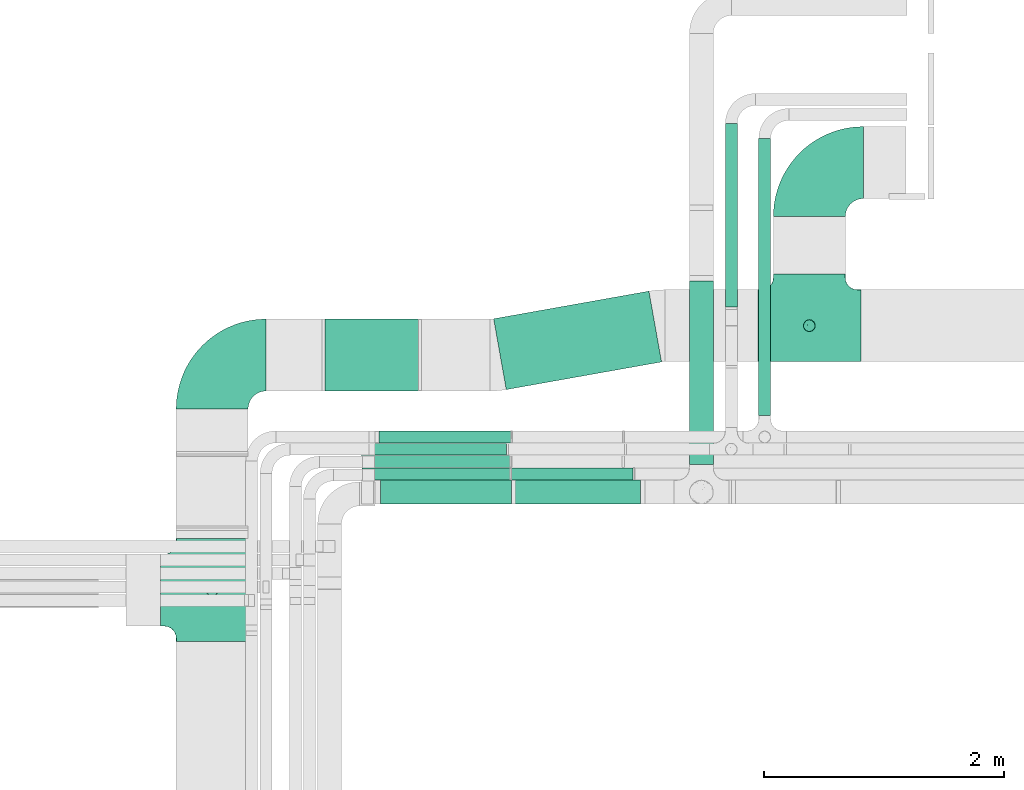
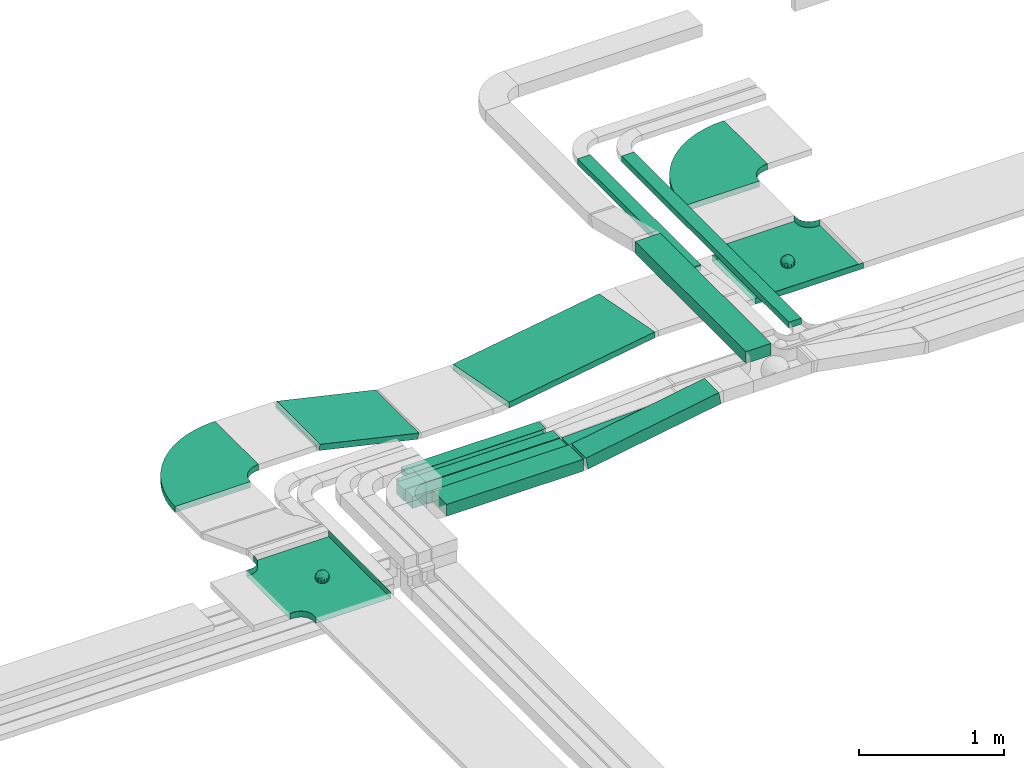
# One storey, part 2 of 28: 12 flow segments, 4 flow fittings.
"""IFC2X3 building model written with IfcOpenShell, lengths in millimetres."""

from ifc_helpers import new_model, entity, si_unit, converted_unit, derived_unit, direction, frame, frame_2d, origin, origin_2d_with_axis, place, context, subcontext, project, spatial, polyline, circle_curve, parameter, trimmed, segment, composite_curve, rectangle, outline, extrude, faceted_brep, source, transform, mapped, material, material_list, type_object, type_shapes, element, save


model = new_model("IFC2X3")

# Units and contexts
model_context = context("Model", 3, precision=0.01, world=origin(), true_north=direction((6.12303176911189e-17, 1.0)))
body_context = subcontext(model_context, "Body", "Model", "MODEL_VIEW")
ifc_project = project(units=[si_unit("LENGTHUNIT", "METRE", prefix="MILLI"), si_unit("AREAUNIT", "SQUARE_METRE"), si_unit("VOLUMEUNIT", "CUBIC_METRE"), converted_unit("PLANEANGLEUNIT", "DEGREE", entity("IfcRatioMeasure", 0.0174532925199433), si_unit("PLANEANGLEUNIT", "RADIAN"), dimensions=[0, 0, 0, 0, 0, 0, 0]), si_unit("MASSUNIT", "GRAM", prefix="KILO"), derived_unit("MASSDENSITYUNIT", [(si_unit("MASSUNIT", "GRAM", prefix="KILO"), 1), (si_unit("LENGTHUNIT", "METRE"), -3)]), derived_unit("MOMENTOFINERTIAUNIT", [(si_unit("LENGTHUNIT", "METRE"), 4)]), si_unit("TIMEUNIT", "SECOND"), si_unit("FREQUENCYUNIT", "HERTZ"), si_unit("THERMODYNAMICTEMPERATUREUNIT", "DEGREE_CELSIUS"), derived_unit("THERMALTRANSMITTANCEUNIT", [(si_unit("MASSUNIT", "GRAM", prefix="KILO"), 1), (si_unit("THERMODYNAMICTEMPERATUREUNIT", "KELVIN"), -1), (si_unit("TIMEUNIT", "SECOND"), -3)]), derived_unit("VOLUMETRICFLOWRATEUNIT", [(si_unit("LENGTHUNIT", "METRE"), 3), (si_unit("TIMEUNIT", "SECOND"), -1)]), derived_unit("MASSFLOWRATEUNIT", [(si_unit("MASSUNIT", "GRAM", prefix="KILO"), 1), (si_unit("TIMEUNIT", "SECOND"), -1)]), derived_unit("ROTATIONALFREQUENCYUNIT", [(si_unit("TIMEUNIT", "SECOND"), -1)]), si_unit("ELECTRICCURRENTUNIT", "AMPERE"), si_unit("ELECTRICVOLTAGEUNIT", "VOLT"), si_unit("POWERUNIT", "WATT"), si_unit("FORCEUNIT", "NEWTON", prefix="KILO"), si_unit("ILLUMINANCEUNIT", "LUX"), si_unit("LUMINOUSFLUXUNIT", "LUMEN"), si_unit("LUMINOUSINTENSITYUNIT", "CANDELA"), derived_unit("USERDEFINED", [(si_unit("MASSUNIT", "GRAM", prefix="KILO"), -1), (si_unit("LENGTHUNIT", "METRE"), -2), (si_unit("TIMEUNIT", "SECOND"), 3), (si_unit("LUMINOUSFLUXUNIT", "LUMEN"), 1)]), derived_unit("LINEARVELOCITYUNIT", [(si_unit("LENGTHUNIT", "METRE"), 1), (si_unit("TIMEUNIT", "SECOND"), -1)]), si_unit("PRESSUREUNIT", "PASCAL"), derived_unit("USERDEFINED", [(si_unit("LENGTHUNIT", "METRE"), -2), (si_unit("MASSUNIT", "GRAM", prefix="KILO"), 1), (si_unit("TIMEUNIT", "SECOND"), -2)]), derived_unit("LINEARFORCEUNIT", [(si_unit("MASSUNIT", "GRAM", prefix="KILO"), 1), (si_unit("LENGTHUNIT", "METRE"), 1), (si_unit("TIMEUNIT", "SECOND"), -2), (si_unit("LENGTHUNIT", "METRE"), -1)]), derived_unit("PLANARFORCEUNIT", [(si_unit("MASSUNIT", "GRAM", prefix="KILO"), 1), (si_unit("LENGTHUNIT", "METRE"), 1), (si_unit("TIMEUNIT", "SECOND"), -2), (si_unit("LENGTHUNIT", "METRE"), -2)])], contexts=[model_context])

# Site, building, storey
site_placement = place(None, origin())
site = spatial("IfcSite", under=ifc_project, at=site_placement, CompositionType="ELEMENT")
building_placement = place(site_placement, origin())
building = spatial("IfcBuilding", under=site, at=building_placement, CompositionType="ELEMENT")
storey_placement = place(building_placement, frame((0.0, 0.0, 4200.0)))
storey = spatial("IfcBuildingStorey", under=building, at=storey_placement, CompositionType="ELEMENT", Elevation=4200.0)

# Flow segments
cable_carrier_segment_type = type_object("IfcCableCarrierSegmentType", PredefinedType="CABLETRAYSEGMENT")
flow_segment_1_placement = place(storey_placement, frame((14783.07, 13087.04, 2750.0)))
element("IfcFlowSegment", 1, at=flow_segment_1_placement, inside=storey, type_object=cable_carrier_segment_type, context=body_context, shape_type="SweptSolid", body=[
    extrude(rectangle(XDim=1530.08411261918, YDim=99.9999999999989, at=origin_2d_with_axis()), frame((50.0, 765.04, 0.0), z_axis=(0.0, 0.0, 1.0), x_axis=(0.0, -1.0, 0.0)), (0.0, 0.0, 1.0), 49.9999999999995),
])
flow_segment_2_placement = place(storey_placement, frame((14483.54, 11773.79, 2904.06)))
element("IfcFlowSegment", 2, at=flow_segment_2_placement, inside=storey, type_object=cable_carrier_segment_type, context=body_context, shape_type="SweptSolid", body=[
    extrude(rectangle(XDim=1529.120177667, YDim=200.000000000002, at=origin_2d_with_axis()), frame((100.0, 764.56, 0.0), z_axis=(0.0, 0.0, 1.0), x_axis=(0.0, 1.0, 0.0)), (0.0, 0.0, 1.0), 99.9999999999989),
])
flow_segment_3_placement = place(storey_placement, frame((15061.77, 12184.03, 2750.0)))
element("IfcFlowSegment", 3, at=flow_segment_3_placement, inside=storey, type_object=cable_carrier_segment_type, context=body_context, shape_type="SweptSolid", body=[
    extrude(rectangle(XDim=2308.09524279726, YDim=99.9999999999989, at=origin_2d_with_axis()), frame((50.0, 1154.05, 0.0), z_axis=(0.0, 0.0, 1.0), x_axis=(0.0, 1.0, 0.0)), (0.0, 0.0, 1.0), 49.9999999999995),
])
flow_segment_4_placement = place(storey_placement, frame((12851.12, 12398.85, 2682.77)))
element("IfcFlowSegment", 4, at=flow_segment_4_placement, inside=storey, type_object=cable_carrier_segment_type, context=body_context, shape_type="SweptSolid", body=[
    extrude(rectangle(XDim=1315.61202745931, YDim=600.000000000002, at=origin_2d_with_axis()), frame((700.22, 410.7, 0.0), z_axis=(0.0, 0.0, 1.0), x_axis=(-0.98450467994016, -0.175358305123892, 0.0)), (0.0, 0.0, 1.0), 49.9999999999995),
])
flow_segment_5_placement = place(storey_placement, frame((13018.46, 11443.79, 2721.49)))
element("IfcFlowSegment", 5, at=flow_segment_5_placement, inside=storey, type_object=cable_carrier_segment_type, context=body_context, shape_type="SweptSolid", body=[
    extrude(rectangle(XDim=100.0, YDim=200.000000000002, at=origin_2d_with_axis()), frame((8.42, 100.0, 49.29), z_axis=(0.98571328393655, 0.0, 0.168431950267823), x_axis=(-0.168431950267823, 0.0, 0.98571328393655)), (0.0, 0.0, 1.0), 1074.28589873588),
])
flow_segment_6_placement = place(storey_placement, frame((11909.09, 11443.79, 2718.43)))
element("IfcFlowSegment", 6, at=flow_segment_6_placement, inside=storey, type_object=cable_carrier_segment_type, context=body_context, shape_type="SweptSolid", body=[
    extrude(rectangle(XDim=1090.17741149844, YDim=199.999999999998, at=origin_2d_with_axis()), frame((545.09, 100.0, 0.0), z_axis=(0.0, 0.0, 1.0), x_axis=(-1.0, 0.0, 0.0)), (0.0, 0.0, 1.0), 99.9999999999989),
])
flow_segment_7_placement = place(storey_placement, frame((11434.39, 12387.05, 2685.9)))
element("IfcFlowSegment", 7, at=flow_segment_7_placement, inside=storey, type_object=cable_carrier_segment_type, context=body_context, shape_type="SweptSolid", body=[
    extrude(rectangle(XDim=49.9999999999999, YDim=600.000000000002, at=frame_2d((0.0, 0.0), x_axis=(0.0, 1.0))), frame((5.58, 300.0, 204.65), z_axis=(0.974806096214138, 0.0, -0.223053972804235), x_axis=(0.0, 1.0, 0.0)), (0.0, 0.0, 1.0), 808.25585556279),
])
flow_segment_8_placement = place(storey_placement, frame((11753.82, 11646.85, 2715.23)))
element("IfcFlowSegment", 8, at=flow_segment_8_placement, inside=storey, type_object=cable_carrier_segment_type, context=body_context, shape_type="SweptSolid", body=[
    extrude(rectangle(XDim=1233.44098848929, YDim=99.9999999999989, at=origin_2d_with_axis()), frame((616.72, 50.0, 0.0), z_axis=(0.0, 0.0, 1.0), x_axis=(-1.0, 0.0, 0.0)), (0.0, 0.0, 1.0), 99.9999999999989),
])
flow_segment_9_placement = place(storey_placement, frame((12999.12, 11646.85, 2715.48)))
element("IfcFlowSegment", 9, at=flow_segment_9_placement, inside=storey, type_object=cable_carrier_segment_type, context=body_context, shape_type="SweptSolid", body=[
    extrude(rectangle(XDim=99.9999999999997, YDim=99.9999999999989, at=frame_2d((0.0, 0.0), x_axis=(0.0, 1.0))), frame((1.69, 50.0, 49.97), z_axis=(0.999429384266034, 0.0, 0.0337772980804675), x_axis=(0.0, 1.0, 0.0)), (0.0, 0.0, 1.0), 1015.96777318739),
])
flow_segment_10_placement = place(storey_placement, frame((11743.82, 11748.96, 2718.4)))
element("IfcFlowSegment", 10, at=flow_segment_10_placement, inside=storey, type_object=cable_carrier_segment_type, context=body_context, shape_type="SweptSolid", body=[
    extrude(rectangle(XDim=1243.22618576762, YDim=99.9999999999989, at=origin_2d_with_axis()), frame((621.61, 50.0, 0.0), z_axis=(0.0, 0.0, 1.0), x_axis=(-1.0, 0.0, 0.0)), (0.0, 0.0, 1.0), 99.9999999999989),
])
flow_segment_11_placement = place(storey_placement, frame((11800.87, 11851.53, 2718.4)))
element("IfcFlowSegment", 11, at=flow_segment_11_placement, inside=storey, type_object=cable_carrier_segment_type, context=body_context, shape_type="SweptSolid", body=[
    extrude(rectangle(XDim=1157.17723915463, YDim=99.9999999999989, at=origin_2d_with_axis()), frame((578.59, 50.0, 0.0), z_axis=(0.0, 0.0, 1.0), x_axis=(-1.0, 0.0, 0.0)), (0.0, 0.0, 1.0), 50.0000000000005),
])
flow_segment_12_placement = place(storey_placement, frame((11895.49, 11954.03, 2718.4)))
element("IfcFlowSegment", 12, at=flow_segment_12_placement, inside=storey, type_object=cable_carrier_segment_type, context=body_context, shape_type="SweptSolid", body=[
    extrude(rectangle(XDim=1098.44771651259, YDim=99.9999999999989, at=origin_2d_with_axis()), frame((549.22, 50.0, 0.0), z_axis=(0.0, 0.0, 1.0), x_axis=(-1.0, 0.0, 0.0)), (0.0, 0.0, 1.0), 49.9999999999995),
])

# Flow fittings
ifc_material_1 = material()
ifc_material_2 = material()
ifc_material_list = material_list([ifc_material_1, ifc_material_2])
cable_carrier_fitting_type_1 = type_object("IfcCableCarrierFittingType", PredefinedType="NOTDEFINED", material=ifc_material_1)
shared_shape_1 = source(origin(), body_context, "Body", "Brep", [
    faceted_brep([(43.65, -13.62, -20.22), (44.77, 0.0, -22.26), (48.26, -5.6, -11.81), (16.66, 5.33, -46.84), (11.56, -8.33, -47.93), (2.02, 2.7, -49.89), (-7.81, -35.95, -33.86), (-17.21, -38.27, -27.19), (-11.13, -27.32, -40.37), (37.7, -7.25, -32.03), (10.64, 26.52, -41.03), (19.21, 19.84, -41.68), (10.42, 17.81, -45.54), (48.75, 0.0, 0.0), (48.07, 6.52, -12.13), (-37.46, 12.16, -30.81), (-31.35, 12.15, -37.01), (-38.09, 3.52, -32.2), (48.75, 11.13, 0.0), (9.67, 42.57, -24.39), (17.48, 37.97, -27.43), (8.35, 35.36, -34.35), (36.7, 20.43, -27.12), (28.22, 12.58, -39.31), (28.4, 24.01, -33.43), (37.1, 7.75, -32.61), (30.39, 38.11, 0.0), (34.74, 34.64, 0.0), (32.94, 32.13, -19.56), (26.04, 41.58, 0.0), (-44.77, 0.0, -22.26), (-35.92, -8.72, -33.67), (-42.7, -12.19, -22.99), (5.42, -48.76, 0.0), (0.0, -48.78, -10.96), (7.59, -47.43, -13.88), (34.0, -31.65, -18.51), (40.01, -26.24, -14.51), (30.39, -38.11, 0.0), (-47.55, -8.65, -12.8), (43.92, -21.15, 0.0), (-47.55, 8.68, -12.81), (-43.92, 21.15, 0.0), (-41.56, 23.54, -14.78), (-36.7, 20.43, -27.12), (-42.68, 12.16, -23.03), (-0.04, -44.68, -22.44), (43.35, 13.13, -21.19), (-9.67, -42.82, -23.94), (2.93, -38.3, -32.0), (10.58, -32.36, -36.62), (17.48, -37.97, -27.43), (29.42, -14.29, -37.82), (29.26, 0.0, -40.54), (-34.74, 34.64, 0.0), (-35.59, 30.87, -16.74), (16.27, 46.29, 0.0), (15.4, 45.37, -14.3), (10.85, 47.52, 0.0), (-22.09, 42.26, -15.04), (-16.27, 46.29, 0.0), (-15.4, 45.37, -14.3), (-35.57, -30.88, -16.76), (-34.74, -34.64, 0.0), (-41.54, -23.57, -14.78), (-21.2, -29.91, -34.0), (-22.09, -42.26, -15.04), (-28.59, -35.77, -20.07), (27.97, -26.92, -31.51), (26.56, -36.75, -21.06), (-4.7, -12.82, -48.1), (-3.71, -22.05, -44.72), (0.0, -29.85, -40.11), (-8.78, 23.47, -43.27), (-10.71, 12.15, -47.3), (-19.19, 19.81, -41.71), (19.21, -19.84, -41.68), (10.27, -43.25, -22.88), (-16.27, -46.29, 0.0), (-15.42, -45.43, -14.08), (-10.85, -47.52, 0.0), (-21.69, -45.05, 0.0), (-26.04, -41.58, 0.0), (-30.39, -38.11, 0.0), (-26.91, -11.71, -40.48), (-28.57, -22.53, -34.29), (-14.35, 0.55, -47.89), (20.39, 29.7, -34.67), (25.88, 35.56, -23.78), (-1.9, 38.3, -32.09), (-0.04, 44.68, -22.44), (-9.54, 42.67, -24.26), (-10.12, 33.04, -36.14), (-17.21, 38.27, -27.19), (-28.59, 35.77, -20.07), (-30.39, 38.11, 0.0), (-26.04, 41.58, 0.0), (-21.69, 45.05, 0.0), (0.92, 16.99, -47.01), (0.0, 29.85, -40.11), (-28.43, 23.64, -33.66), (22.08, -42.72, -13.7), (0.0, -50.0, 0.0), (-7.98, 47.29, -14.15), (-10.85, 47.52, 0.0), (-5.42, 48.76, 0.0), (-39.09, -31.17, 0.0), (-36.7, -20.43, -27.12), (-20.05, 29.88, -34.71), (48.75, -11.13, 0.0), (36.7, -20.43, -27.12), (39.09, -31.17, 0.0), (43.92, 21.15, 0.0), (41.04, 24.48, -14.72), (21.43, -9.87, -44.08), (19.85, -30.3, -34.47), (26.04, -41.58, 0.0), (8.28, -22.62, -43.82), (-19.19, -19.81, -41.71), (-17.56, -9.66, -45.81), (-29.26, 0.0, -40.54), (-22.28, 8.45, -43.96), (21.69, -45.05, 0.0), (-7.75, -47.32, -14.15), (22.09, 42.36, -14.75), (21.69, 45.05, 0.0), (7.94, 47.25, -14.29), (5.42, 48.76, 0.0), (-43.92, -21.15, 0.0), (-39.09, 31.17, 0.0), (-48.75, 11.13, 0.0), (-48.75, -11.13, 0.0), (-48.75, 0.0, 0.0), (0.0, 50.0, 0.0), (0.0, 48.77, -11.04), (-5.42, -48.76, 0.0), (16.27, -46.29, 0.0), (10.85, -47.52, 0.0), (39.09, 31.17, 0.0), (34.74, -34.64, 0.0), (-43.65, -13.62, 20.22), (-44.77, 0.0, 22.26), (-48.26, -5.6, 11.81), (-16.66, 5.33, 46.84), (-11.56, -8.33, 47.93), (-2.02, 2.7, 49.89), (7.81, -35.95, 33.86), (17.21, -38.27, 27.19), (11.13, -27.32, 40.37), (-37.7, -7.25, 32.03), (-10.64, 26.52, 41.03), (-19.21, 19.84, 41.68), (-10.42, 17.81, 45.54), (-48.07, 6.52, 12.13), (37.46, 12.16, 30.81), (31.35, 12.15, 37.01), (38.09, 3.52, 32.2), (-9.67, 42.57, 24.39), (-17.48, 37.97, 27.43), (-8.35, 35.36, 34.35), (-36.7, 20.43, 27.12), (-28.22, 12.58, 39.31), (-28.4, 24.01, 33.43), (-37.1, 7.75, 32.61), (-32.94, 32.13, 19.56), (44.77, 0.0, 22.26), (35.92, -8.72, 33.67), (42.7, -12.19, 22.99), (0.0, -48.78, 10.96), (-7.59, -47.43, 13.88), (-34.0, -31.65, 18.51), (-40.01, -26.24, 14.51), (47.55, -8.65, 12.8), (47.55, 8.68, 12.81), (41.56, 23.54, 14.78), (36.7, 20.43, 27.12), (42.68, 12.16, 23.03), (0.04, -44.68, 22.44), (-43.35, 13.13, 21.19), (9.67, -42.82, 23.94), (-2.93, -38.3, 32.0), (-10.58, -32.36, 36.62), (-17.48, -37.97, 27.43), (-29.42, -14.29, 37.82), (-29.26, 0.0, 40.54), (35.59, 30.87, 16.74), (-15.4, 45.37, 14.3), (22.09, 42.26, 15.04), (15.4, 45.37, 14.3), (35.57, -30.88, 16.76), (41.54, -23.57, 14.78), (21.2, -29.91, 34.0), (22.09, -42.26, 15.04), (28.59, -35.77, 20.07), (-27.97, -26.92, 31.51), (-26.56, -36.75, 21.06), (4.7, -12.82, 48.1), (3.71, -22.05, 44.72), (0.0, -29.85, 40.11), (8.78, 23.47, 43.27), (10.71, 12.15, 47.3), (19.19, 19.81, 41.71), (-19.21, -19.84, 41.68), (-10.27, -43.25, 22.88), (15.42, -45.43, 14.08), (26.91, -11.71, 40.48), (28.57, -22.53, 34.29), (14.35, 0.55, 47.89), (-20.39, 29.7, 34.67), (-25.88, 35.56, 23.78), (1.9, 38.3, 32.09), (0.04, 44.68, 22.44), (9.54, 42.67, 24.26), (10.12, 33.04, 36.14), (17.21, 38.27, 27.19), (28.59, 35.77, 20.07), (-0.92, 16.99, 47.01), (0.0, 29.85, 40.11), (28.43, 23.64, 33.66), (-22.08, -42.72, 13.7), (7.98, 47.29, 14.15), (36.7, -20.43, 27.12), (20.05, 29.88, 34.71), (-36.7, -20.43, 27.12), (-41.04, 24.48, 14.72), (-21.43, -9.87, 44.08), (-19.85, -30.3, 34.47), (-8.28, -22.62, 43.82), (19.19, -19.81, 41.71), (17.56, -9.66, 45.81), (29.26, 0.0, 40.54), (22.28, 8.45, 43.96), (7.75, -47.32, 14.15), (-22.09, 42.36, 14.75), (-7.94, 47.25, 14.29), (0.0, 48.77, 11.04)], [[[0, 1, 2]], [[3, 4, 5]], [[6, 7, 8]], [[1, 0, 9]], [[10, 11, 12]], [[13, 2, 14]], [[15, 16, 17]], [[14, 18, 13]], [[19, 20, 21]], [[22, 23, 24]], [[1, 9, 25]], [[26, 27, 28, 29]], [[30, 31, 32]], [[33, 34, 35]], [[36, 37, 38]], [[32, 39, 30]], [[2, 40, 0]], [[23, 22, 25]], [[41, 42, 43]], [[44, 15, 45]], [[46, 35, 34]], [[25, 22, 47]], [[31, 30, 17]], [[48, 49, 46]], [[50, 51, 49]], [[52, 53, 9]], [[43, 54, 55]], [[56, 57, 58]], [[59, 60, 61]], [[62, 63, 64]], [[8, 7, 65]], [[7, 66, 67]], [[68, 36, 69]], [[70, 5, 4]], [[8, 71, 72]], [[73, 74, 75]], [[68, 76, 52]], [[77, 46, 49]], [[78, 79, 80]], [[7, 6, 48]], [[67, 81, 82, 83]], [[84, 85, 31]], [[85, 65, 67]], [[70, 86, 5]], [[23, 3, 11]], [[21, 87, 10]], [[21, 20, 87]], [[28, 24, 88]], [[19, 89, 90]], [[91, 90, 89]], [[91, 92, 93]], [[94, 95, 96, 97]], [[98, 99, 10]], [[100, 16, 44]], [[77, 51, 101]], [[33, 102, 34]], [[103, 91, 61]], [[93, 59, 61]], [[104, 105, 103]], [[106, 64, 63]], [[107, 31, 85]], [[100, 94, 108]], [[108, 93, 92]], [[43, 55, 44]], [[0, 40, 37]], [[2, 13, 109]], [[2, 1, 14]], [[110, 9, 0]], [[2, 109, 40]], [[37, 40, 111]], [[47, 14, 1]], [[112, 14, 47]], [[113, 112, 47]], [[112, 18, 14]], [[47, 22, 113]], [[52, 9, 110]], [[53, 25, 9]], [[25, 47, 1]], [[23, 25, 53]], [[68, 52, 110]], [[76, 4, 114]], [[51, 115, 69]], [[50, 115, 51]], [[110, 36, 68]], [[3, 23, 53]], [[23, 11, 24]], [[52, 76, 114]], [[98, 12, 5]], [[11, 87, 24]], [[24, 28, 22]], [[87, 88, 24]], [[36, 116, 69]], [[28, 27, 113]], [[114, 3, 53]], [[76, 115, 117]], [[70, 4, 117]], [[118, 84, 119]], [[119, 70, 118]], [[120, 16, 121]], [[37, 36, 110]], [[116, 36, 38]], [[116, 122, 69]], [[34, 123, 46]], [[10, 87, 11]], [[87, 20, 88]], [[12, 98, 10]], [[10, 99, 21]], [[74, 5, 86]], [[73, 75, 108]], [[124, 56, 125]], [[124, 29, 88]], [[89, 21, 99]], [[21, 89, 19]], [[92, 89, 99]], [[89, 92, 91]], [[126, 127, 58]], [[88, 29, 28]], [[20, 57, 124]], [[88, 20, 124]], [[57, 20, 19]], [[73, 92, 99]], [[92, 73, 108]], [[99, 98, 73]], [[74, 86, 121]], [[73, 98, 74]], [[5, 74, 98]], [[100, 108, 75]], [[94, 93, 108]], [[86, 120, 121]], [[100, 44, 55]], [[75, 16, 100]], [[17, 16, 120]], [[31, 17, 120]], [[17, 30, 45]], [[84, 31, 120]], [[31, 107, 32]], [[41, 45, 30]], [[43, 44, 45]], [[107, 64, 32]], [[39, 64, 128]], [[30, 39, 41]], [[129, 43, 42]], [[41, 130, 42]], [[43, 45, 41]], [[62, 83, 63]], [[95, 94, 55]], [[100, 55, 94]], [[64, 107, 62]], [[131, 39, 128]], [[64, 106, 128]], [[85, 62, 107]], [[67, 83, 62]], [[39, 32, 64]], [[130, 41, 132]], [[59, 97, 60]], [[133, 127, 134]], [[59, 94, 97]], [[104, 61, 60]], [[94, 59, 93]], [[126, 134, 127]], [[126, 58, 57]], [[19, 90, 126]], [[134, 105, 133]], [[126, 90, 134]], [[103, 90, 91]], [[105, 134, 103]], [[90, 103, 134]], [[119, 120, 86]], [[84, 118, 85]], [[65, 85, 118]], [[62, 85, 67]], [[8, 65, 118]], [[67, 65, 7]], [[71, 118, 70]], [[8, 72, 6]], [[49, 6, 72]], [[6, 49, 48]], [[50, 49, 72]], [[77, 49, 51]], [[101, 69, 122]], [[123, 34, 135]], [[101, 122, 136]], [[137, 77, 136]], [[78, 81, 66]], [[7, 79, 66]], [[67, 66, 81]], [[79, 7, 48]], [[35, 137, 33]], [[123, 80, 79]], [[135, 34, 102]], [[35, 46, 77]], [[80, 123, 135]], [[46, 123, 48]], [[117, 50, 72]], [[115, 76, 68]], [[117, 72, 71]], [[4, 76, 117]], [[39, 132, 41]], [[39, 131, 132]], [[137, 35, 77]], [[124, 57, 56]], [[126, 57, 19]], [[103, 61, 104]], [[61, 91, 93]], [[77, 101, 136]], [[51, 69, 101]], [[28, 113, 22]], [[112, 113, 138]], [[16, 75, 121]], [[74, 121, 75]], [[66, 79, 78]], [[123, 79, 48]], [[0, 37, 110]], [[37, 111, 139, 38]], [[29, 124, 125]], [[115, 50, 117]], [[69, 115, 68]], [[120, 119, 84]], [[70, 119, 86]], [[11, 3, 12]], [[5, 12, 3]], [[118, 71, 8]], [[117, 71, 70]], [[3, 114, 4]], [[53, 52, 114]], [[27, 138, 113]], [[45, 15, 17]], [[44, 16, 15]], [[55, 54, 95]], [[43, 129, 54]], [[140, 141, 142]], [[143, 144, 145]], [[146, 147, 148]], [[141, 140, 149]], [[150, 151, 152]], [[132, 142, 153]], [[154, 155, 156]], [[153, 130, 132]], [[157, 158, 159]], [[160, 161, 162]], [[141, 149, 163]], [[95, 54, 164, 96]], [[165, 166, 167]], [[135, 168, 169]], [[170, 171, 83]], [[167, 172, 165]], [[142, 141, 153]], [[161, 160, 163]], [[173, 112, 174]], [[175, 154, 176]], [[177, 169, 168]], [[163, 160, 178]], [[166, 165, 156]], [[179, 180, 177]], [[181, 182, 180]], [[183, 184, 149]], [[174, 27, 185]], [[60, 186, 104]], [[187, 56, 188]], [[189, 139, 190]], [[148, 147, 191]], [[147, 192, 193]], [[194, 170, 195]], [[196, 145, 144]], [[148, 197, 198]], [[199, 200, 201]], [[194, 202, 183]], [[203, 177, 180]], [[136, 204, 137]], [[147, 146, 179]], [[193, 122, 116, 38]], [[205, 206, 166]], [[206, 191, 193]], [[196, 207, 145]], [[161, 143, 151]], [[159, 208, 150]], [[159, 158, 208]], [[164, 162, 209]], [[157, 210, 211]], [[212, 211, 210]], [[212, 213, 214]], [[215, 26, 29, 125]], [[216, 217, 150]], [[218, 155, 175]], [[203, 182, 219]], [[135, 102, 168]], [[220, 212, 188]], [[214, 187, 188]], [[58, 127, 220]], [[111, 190, 139]], [[221, 166, 206]], [[218, 215, 222]], [[222, 214, 213]], [[174, 185, 175]], [[171, 140, 128]], [[132, 131, 142]], [[142, 128, 140]], [[223, 149, 140]], [[142, 131, 128]], [[171, 128, 106]], [[178, 153, 141]], [[42, 153, 178]], [[224, 42, 178]], [[42, 130, 153]], [[178, 160, 224]], [[183, 149, 223]], [[184, 163, 149]], [[163, 178, 141]], [[161, 163, 184]], [[194, 183, 223]], [[202, 144, 225]], [[182, 226, 195]], [[181, 226, 182]], [[223, 170, 194]], [[143, 161, 184]], [[161, 151, 162]], [[183, 202, 225]], [[216, 152, 145]], [[151, 208, 162]], [[162, 164, 160]], [[208, 209, 162]], [[170, 82, 195]], [[164, 54, 224]], [[225, 143, 184]], [[202, 226, 227]], [[196, 144, 227]], [[228, 205, 229]], [[229, 196, 228]], [[230, 155, 231]], [[171, 170, 223]], [[82, 170, 83]], [[82, 81, 195]], [[168, 232, 177]], [[150, 208, 151]], [[208, 158, 209]], [[152, 216, 150]], [[150, 217, 159]], [[200, 145, 207]], [[199, 201, 222]], [[233, 60, 97]], [[233, 96, 209]], [[210, 159, 217]], [[159, 210, 157]], [[213, 210, 217]], [[210, 213, 212]], [[234, 105, 104]], [[209, 96, 164]], [[158, 186, 233]], [[209, 158, 233]], [[186, 158, 157]], [[199, 213, 217]], [[213, 199, 222]], [[217, 216, 199]], [[200, 207, 231]], [[199, 216, 200]], [[145, 200, 216]], [[218, 222, 201]], [[215, 214, 222]], [[207, 230, 231]], [[218, 175, 185]], [[201, 155, 218]], [[156, 155, 230]], [[166, 156, 230]], [[156, 165, 176]], [[205, 166, 230]], [[166, 221, 167]], [[173, 176, 165]], [[174, 175, 176]], [[221, 190, 167]], [[172, 190, 40]], [[165, 172, 173]], [[138, 174, 112]], [[173, 18, 112]], [[174, 176, 173]], [[189, 38, 139]], [[26, 215, 185]], [[218, 185, 215]], [[190, 221, 189]], [[109, 172, 40]], [[190, 111, 40]], [[206, 189, 221]], [[193, 38, 189]], [[172, 167, 190]], [[18, 173, 13]], [[187, 125, 56]], [[133, 105, 235]], [[187, 215, 125]], [[58, 188, 56]], [[215, 187, 214]], [[234, 235, 105]], [[234, 104, 186]], [[157, 211, 234]], [[235, 127, 133]], [[234, 211, 235]], [[220, 211, 212]], [[127, 235, 220]], [[211, 220, 235]], [[229, 230, 207]], [[205, 228, 206]], [[191, 206, 228]], [[189, 206, 193]], [[148, 191, 228]], [[193, 191, 147]], [[197, 228, 196]], [[148, 198, 146]], [[180, 146, 198]], [[146, 180, 179]], [[181, 180, 198]], [[203, 180, 182]], [[219, 195, 81]], [[232, 168, 33]], [[219, 81, 78]], [[80, 203, 78]], [[136, 122, 192]], [[147, 204, 192]], [[193, 192, 122]], [[204, 147, 179]], [[169, 80, 135]], [[232, 137, 204]], [[33, 168, 102]], [[169, 177, 203]], [[137, 232, 33]], [[177, 232, 179]], [[227, 181, 198]], [[226, 202, 194]], [[227, 198, 197]], [[144, 202, 227]], [[172, 13, 173]], [[172, 109, 13]], [[80, 169, 203]], [[233, 186, 60]], [[234, 186, 157]], [[220, 188, 58]], [[188, 212, 214]], [[203, 219, 78]], [[182, 195, 219]], [[164, 224, 160]], [[42, 224, 129]], [[155, 201, 231]], [[200, 231, 201]], [[192, 204, 136]], [[232, 204, 179]], [[140, 171, 223]], [[171, 106, 63, 83]], [[96, 233, 97]], [[226, 181, 227]], [[195, 226, 194]], [[230, 229, 205]], [[196, 229, 207]], [[151, 143, 152]], [[145, 152, 143]], [[228, 197, 148]], [[227, 197, 196]], [[143, 225, 144]], [[184, 183, 225]], [[54, 129, 224]], [[176, 154, 156]], [[175, 155, 154]], [[185, 27, 26]], [[174, 138, 27]]]),
    faceted_brep([(-303.41, -374.12, 25.0), (-300.0, -400.0, 25.0), (-300.0, -430.0, 25.0), (-299.2, -430.0, 25.0), (-299.2, -400.0, 25.0), (-302.63, -373.91, 25.0), (-312.7, -349.6, 25.0), (-328.72, -328.72, 25.0), (-349.6, -312.7, 25.0), (-373.91, -302.63, 25.0), (-400.0, -299.2, 25.0), (-430.0, -299.2, 25.0), (-430.0, -300.0, 25.0), (-400.0, -300.0, 25.0), (-374.12, -303.41, 25.0), (-350.0, -313.4, 25.0), (-329.29, -329.29, 25.0), (-313.4, -350.0, 25.0), (430.0, -300.0, 25.0), (430.0, -299.2, 25.0), (400.0, -299.2, 25.0), (373.91, -302.63, 25.0), (349.6, -312.7, 25.0), (328.72, -328.72, 25.0), (312.7, -349.6, 25.0), (302.63, -373.91, 25.0), (299.2, -400.0, 25.0), (299.2, -430.0, 25.0), (300.0, -430.0, 25.0), (300.0, -400.0, 25.0), (303.41, -374.12, 25.0), (313.4, -350.0, 25.0), (329.29, -329.29, 25.0), (350.0, -313.4, 25.0), (374.12, -303.41, 25.0), (400.0, -300.0, 25.0), (430.0, 299.2, 25.0), (430.0, 300.0, 25.0), (-430.0, 300.0, 25.0), (-430.0, 299.2, 25.0), (-430.0, -300.0, -25.0), (-430.0, 300.0, -25.0), (430.0, 300.0, -25.0), (430.0, -300.0, -25.0), (400.0, -300.0, -25.0), (374.12, -303.41, -25.0), (350.0, -313.4, -25.0), (329.29, -329.29, -25.0), (313.4, -350.0, -25.0), (303.41, -374.12, -25.0), (300.0, -400.0, -25.0), (300.0, -430.0, -25.0), (-300.0, -430.0, -25.0), (-300.0, -400.0, -25.0), (-303.41, -374.12, -25.0), (-313.4, -350.0, -25.0), (-329.29, -329.29, -25.0), (-350.0, -313.4, -25.0), (-374.12, -303.41, -25.0), (-400.0, -300.0, -25.0), (-300.0, -400.0, -24.2), (299.2, -430.0, -24.2), (-299.2, -430.0, -24.2), (-299.2, -400.0, -24.2), (-400.0, -299.2, -24.2), (-430.0, -299.2, -24.2), (430.0, -299.2, -24.2), (400.0, -299.2, -24.2), (-430.0, 299.2, -24.2), (-400.0, -300.0, -24.2), (400.0, -300.0, -24.2), (430.0, 299.2, -24.2), (299.2, -400.0, -24.2), (300.0, -400.0, -24.2), (-373.91, -302.63, -24.2), (-349.6, -312.7, -24.2), (-328.72, -328.72, -24.2), (-312.7, -349.6, -24.2), (-302.63, -373.91, -24.2), (302.63, -373.91, -24.2), (312.7, -349.6, -24.2), (328.72, -328.72, -24.2), (349.6, -312.7, -24.2), (373.91, -302.63, -24.2)], [[[0, 1, 2, 3, 4, 5, 6, 7, 8, 9, 10, 11, 12, 13, 14, 15, 16, 17]], [[18, 19, 20, 21, 22, 23, 24, 25, 26, 27, 28, 29, 30, 31, 32, 33, 34, 35]], [[36, 37, 38, 39]], [[40, 41, 42, 43, 44, 45, 46, 47, 48, 49, 50, 51, 52, 53, 54, 55, 56, 57, 58, 59]], [[2, 1, 60, 53, 52]], [[3, 2, 52, 51, 28, 27, 61, 62]], [[4, 3, 62, 63]], [[11, 10, 64, 65]], [[20, 19, 66, 67]], [[39, 38, 41, 40, 12, 11, 65, 68]], [[13, 12, 40, 59, 69]], [[18, 35, 70, 44, 43]], [[19, 18, 43, 42, 37, 36, 71, 66]], [[27, 26, 72, 61]], [[29, 28, 51, 50, 73]], [[38, 37, 42, 41]], [[36, 39, 68, 71]], [[68, 65, 64, 74, 75, 76, 77, 78, 63, 62, 61, 72, 79, 80, 81, 82, 83, 67, 66, 71]], [[14, 13, 69, 59, 58]], [[58, 57, 15, 14]], [[15, 57, 56, 16]], [[0, 17, 55, 54]], [[0, 54, 53, 60, 1]], [[55, 17, 16, 56]], [[5, 4, 63, 78]], [[6, 5, 78, 77]], [[7, 6, 77, 76]], [[8, 7, 76, 75]], [[9, 8, 75, 74]], [[10, 9, 74, 64]], [[21, 20, 67, 83]], [[22, 21, 83, 82]], [[23, 22, 82, 81]], [[81, 80, 24, 23]], [[24, 80, 79, 25]], [[79, 72, 26, 25]], [[30, 29, 73, 50, 49]], [[31, 30, 49, 48]], [[31, 48, 47, 32]], [[33, 32, 47, 46]], [[45, 34, 33, 46]], [[34, 45, 44, 70, 35]]]),
])
type_shapes(cable_carrier_fitting_type_1, [shared_shape_1])
for number, where, z_axis, x_axis, name in (
    (13, (15484.08, 12932.05, 2707.77), (0.0, 0.0, 1.0), (-1.0, 0.0, 0.0), "470_DKC_S5_T"),
    (14, (10503.59, 10726.35, 3135.0), (0.0, 0.0, 1.0), (0.0, -1.0, 0.0), "470_DKC_S5_T"),
):
    element("IfcFlowFitting", number, at=place(storey_placement, frame(where, z_axis=z_axis, x_axis=x_axis)), inside=storey, type_object=cable_carrier_fitting_type_1, material=ifc_material_list, Name=name, context=body_context, shape_type="MappedRepresentation", body=[
        mapped(shared_shape_1, transform((0.0, 0.0, 0.0), scale=1.0)),
    ])
cable_carrier_fitting_type_2 = type_object("IfcCableCarrierFittingType", Name="470_DKC_S5_Variable Angle Elbow 0-45:-", PredefinedType="NOTDEFINED", material=ifc_material_2)
shared_shape_2 = source(origin(), body_context, "Body", "SweptSolid", [
    extrude(outline(composite_curve([segment(polyline([(-225.75, -525.25), (-224.75, -525.25)]), True, "CONTINUOUS"), segment(trimmed(circle_curve(frame_2d((-224.75, 224.75), x_axis=(0.0, -1.0)), 750.0), [parameter(0.0)], [parameter(90.0)], True, "PARAMETER"), True, "CONTINUOUS"), segment(polyline([(525.25, 224.75), (525.25, 225.75)]), True, "CONTINUOUS"), segment(polyline([(525.25, 225.75), (-74.75, 225.75)]), True, "CONTINUOUS"), segment(polyline([(-74.75, 225.75), (-74.75, 224.75)]), True, "CONTINUOUS"), segment(trimmed(circle_curve(frame_2d((-224.75, 224.75), x_axis=(0.0, -1.0)), 150.0), [parameter(0.0)], [parameter(90.0000000000001)], True, "PARAMETER"), False, "CONTINUOUS"), segment(polyline([(-224.75, 74.75), (-225.75, 74.75)]), True, "CONTINUOUS"), segment(polyline([(-225.75, 74.75), (-225.75, -525.25)]), True, "CONTINUOUS")], self_intersect=False)), frame((-225.25, 225.25, -25.0)), (0.0, 0.0, 1.0), 50.0000000000082),
])
type_shapes(cable_carrier_fitting_type_2, [shared_shape_2])
for number, where, z_axis, x_axis, name in (
    (15, (15484.08, 14292.05, 2707.77), (0.0, 0.0, 1.0), (-1.0, 0.0, 0.0), "470_DKC_S5_Variable Angle Elbow 0-45:-"),
    (16, (10503.59, 12687.05, 2893.06), (0.0, 0.0, 1.0), (-1.0, 0.0, 0.0), "470_DKC_S5_Variable Angle Elbow 0-45:-"),
):
    element("IfcFlowFitting", number, at=place(storey_placement, frame(where, z_axis=z_axis, x_axis=x_axis)), inside=storey, type_object=cable_carrier_fitting_type_2, material=ifc_material_2, Name=name, ObjectType="470_DKC_S5_Variable Angle Elbow 0-45:-", context=body_context, shape_type="MappedRepresentation", body=[
        mapped(shared_shape_2, transform((0.0, 0.0, 0.0), scale=1.0)),
    ])

save(model, "model.ifc")
